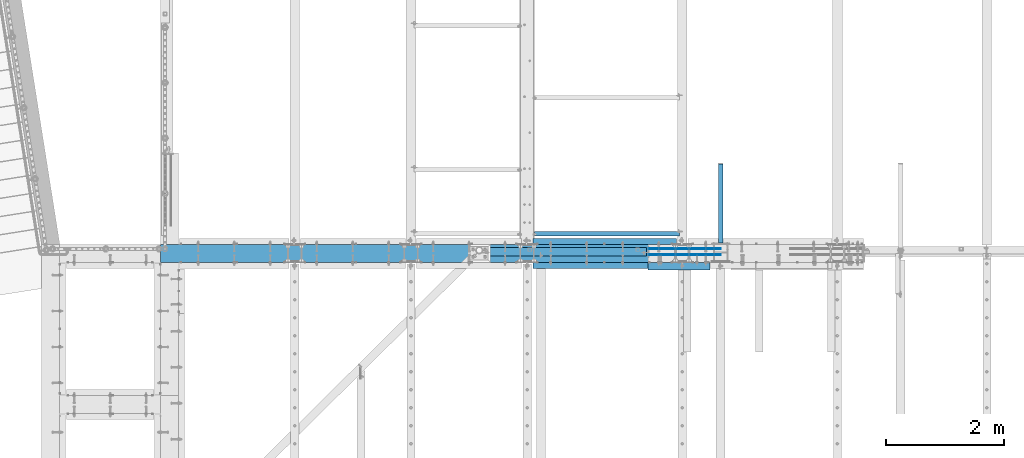
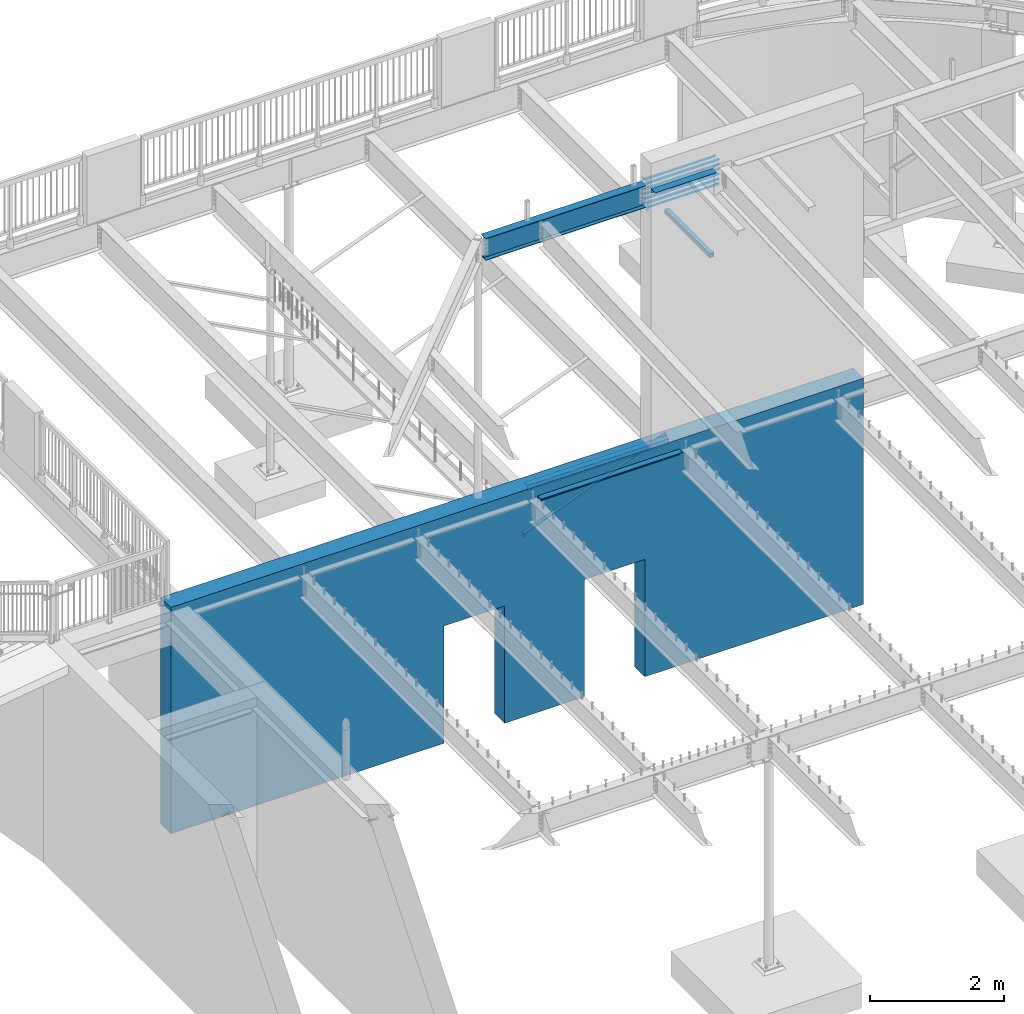
# One storey, part 320 of 975: 19 beams.
"""IFC2X3 building model written with IfcOpenShell, lengths in millimetres."""

from ifc_helpers import new_model, si_unit, frame, origin_with_axes, place, context, subcontext, project, spatial, faceted_brep, material, type_object, element, save


model = new_model("IFC2X3")

# Units and contexts
model_context = context("Model", 3, precision=1e-05, world=origin_with_axes())
body_context = subcontext(model_context, "Body", "Model", "MODEL_VIEW")
ifc_project = project(units=[si_unit("LENGTHUNIT", "METRE", prefix="MILLI"), si_unit("AREAUNIT", "SQUARE_METRE"), si_unit("VOLUMEUNIT", "CUBIC_METRE"), si_unit("MASSUNIT", "GRAM", prefix="KILO"), si_unit("TIMEUNIT", "SECOND"), si_unit("PLANEANGLEUNIT", "RADIAN"), si_unit("SOLIDANGLEUNIT", "STERADIAN"), si_unit("THERMODYNAMICTEMPERATUREUNIT", "DEGREE_CELSIUS"), si_unit("LUMINOUSINTENSITYUNIT", "LUMEN")], contexts=[model_context])

# Site, building, storey
site_placement = place(None, origin_with_axes())
site = spatial("IfcSite", under=ifc_project, at=site_placement, CompositionType="ELEMENT")
building_placement = place(site_placement, origin_with_axes())
building = spatial("IfcBuilding", under=site, at=building_placement, Name="Undefined", CompositionType="ELEMENT")
storey_placement = place(building_placement, origin_with_axes())
storey = spatial("IfcBuildingStorey", under=building, at=storey_placement, Name="Undefined", CompositionType="ELEMENT", Elevation=0.0)

# Beams
ifc_material_1 = material(Name="STEEL/A36")
beam_type_1 = type_object("IfcBeamType", Name="L3X3X3/16", PredefinedType="NOTDEFINED")
beam_1_placement = place(storey_placement, frame((8394.7, 20924.04375, 2870.2), z_axis=(0.0, -1.0, 0.0), x_axis=(0.0, 0.0, 1.0)))
element("IfcBeam", 1, at=beam_1_placement, inside=storey, type_object=beam_type_1, material=ifc_material_1, Name="ANGLE", ObjectType="L3X3X3/16", context=body_context, shape_type="Brep", body=[
    faceted_brep([(39.9761162779782, -38.1000000000186, -33.3375000000015), (39.9761162779782, -38.1000000000186, -38.0999999999985), (975.885837340196, -2441.28615210523, -38.0999999999985), (975.885837340196, -2441.28615210523, -33.3375000000015), (92.0750045805971, 38.0999999999585, 38.0999999999985), (92.0750045776413, 38.0999999999985, -38.1000000000004), (25.4000000000001, 38.0999999999985, -38.1000000000004), (25.4000000005876, 38.0999999999876, 38.0999999999985), (1046.89123738925, -2413.6334277571, 38.0999999999985), (1046.89123738925, -2413.6334277571, -38.0999999999985), (22.2348571728535, 7.45519597605016, -38.0999999999985), (88.8737698161085, 33.4074081533654, -38.0999999999985), (25.4037304659755, 33.357482595593, -38.0999999999985), (88.8737698161085, 33.4074081533654, -33.3375000000015), (22.2348571728535, 7.45519597605016, -33.3375000000015), (25.4037304659819, 33.3574825875421, -33.3375000000015), (25.4037304659746, 33.3574825966371, 38.0999999999985), (88.8188240616832, 33.3374999999596, 38.0999999999985), (1042.45405198512, -2415.36146907195, -33.3375000000015), (1042.45339988618, -2415.36172302886, 38.0999999999985)], [[[0, 1, 2, 3]], [[4, 5, 6, 7]], [[5, 4, 8, 9]], [[1, 10, 11, 12, 6, 5, 9, 2]], [[13, 11, 10, 14]], [[11, 13, 15, 12]], [[16, 7, 6, 12, 15]], [[13, 17, 16, 15]], [[17, 13, 18, 19]], [[4, 7, 16, 17, 19, 8]], [[18, 3, 2, 9, 8, 19]], [[13, 14, 0, 3, 18]], [[10, 1, 0, 14]]]),
])
beam_type_2 = type_object("IfcBeamType", Name="L4X4X5/16", PredefinedType="NOTDEFINED")
for number, where, z_axis, x_axis, name in (
    (2, (10763.249999995, 20799.4249996637, 3886.2), (0.0, 1.0, 0.0), (-0.999999999999998, 6.90000001668524e-08, 0.0), "LEDGER_ANGLE"),
    (3, (8324.84999999089, 20393.025, 3886.2), (0.0, -1.0, 0.0), (1.0, 0.0, 0.0), "LEDGER_ANGLE"),
):
    element("IfcBeam", number, at=place(storey_placement, frame(where, z_axis=z_axis, x_axis=x_axis)), inside=storey, type_object=beam_type_2, material=ifc_material_1, Name=name, ObjectType="L4X4X5/16", context=body_context, shape_type="Brep", body=[
        faceted_brep([(-1.90993887372315e-11, 50.8000000000002, -50.8), (2.00088834390044e-11, 50.8000000000002, 50.8), (2438.40000000415, 50.8000000000002, 50.7999999999993), (2438.40000000415, 50.8000000000002, -50.7999999999993), (2.00088834390044e-11, 42.8625000000002, 50.8), (2438.40000000415, 42.8625000000002, 50.7999999999993), (-1.63709046319127e-11, 42.8625000000002, -42.8625), (2438.40000000415, 42.8625000000002, -42.8624999999993), (-1.63709046319127e-11, -50.8000000000002, -42.8625), (2438.40000000415, -50.8000000000002, -42.8624999999993), (-1.90993887372315e-11, -50.8000000000002, -50.8), (2438.40000000415, -50.8000000000002, -50.7999999999993)], [[[0, 1, 2, 3]], [[1, 4, 5, 2]], [[4, 6, 7, 5]], [[6, 8, 9, 7]], [[8, 10, 11, 9]], [[10, 0, 3, 11]], [[5, 7, 9, 11, 3, 2]], [[10, 8, 6, 4, 1, 0]]]),
    ])
beam_type_3 = type_object("IfcBeamType", Name="L5X3X5/16", PredefinedType="NOTDEFINED")
beam_2_placement = place(storey_placement, frame((10274.2999999151, 20380.325, 8801.1), z_axis=(0.0, -1.0, 0.0), x_axis=(1.0, 0.0, 0.0)))
element("IfcBeam", 4, at=beam_2_placement, inside=storey, type_object=beam_type_3, material=ifc_material_1, Name="LEDGER_ANGLE", ObjectType="L5X3X5/16", context=body_context, shape_type="Brep", body=[
    faceted_brep([(5.0931703299284e-11, 38.0999999999999, -63.5000000000255), (-4.72937244921923e-11, 38.0999999999999, 63.5000000000182), (1057.27499999998, 38.1000000000004, 63.5000000004693), (1057.27500000004, 38.1000000000004, -63.4999999995307), (-3.63797880709171e-12, 30.1625000000404, 63.4999999999909), (1057.27499999998, 30.1625000000004, 63.5000000004693), (3.41060513164848e-12, 30.1624999999367, -55.5625000000091), (1057.27500000003, 30.1625000000004, -55.5624999995307), (2.27373675443232e-12, -38.1000000000313, -55.5624999999873), (1057.27500000003, -38.1000000000004, -55.5624999995307), (5.0931703299284e-11, -38.0999999999999, -63.5000000000255), (1057.27500000004, -38.1000000000004, -63.4999999995307)], [[[0, 1, 2, 3]], [[1, 4, 5, 2]], [[4, 6, 7, 5]], [[6, 8, 9, 7]], [[8, 10, 11, 9]], [[10, 0, 3, 11]], [[5, 7, 9, 11, 3, 2]], [[10, 8, 6, 4, 1, 0]]]),
])
ifc_material_2 = material(Name="STEEL/A496")
beam_type_4 = type_object("IfcBeamType", Name="#6 DBA", PredefinedType="NOTDEFINED")
for number, where, z_axis, x_axis, name in (
    (5, (10293.3500068517, 20570.8249983747, 8772.53493098976), (0.0, -1.0, 0.0), (1.0, 0.0, 0.0), "ROD"),
    (6, (10293.3500072578, 20672.4249983747, 8772.53493100593), (0.0, -1.0, 0.0), (1.0, 0.0, 0.0), "ROD"),
    (7, (10293.3500068517, 20570.8249983925, 8683.6349431141), (0.0, -1.0, 0.0), (1.0, 0.0, 0.0), "ROD"),
    (8, (10293.3500072578, 20672.4249983925, 8683.63494313028), (0.0, -1.0, 0.0), (1.0, 0.0, 0.0), "ROD"),
    (9, (10293.3500068517, 20570.8249984103, 8594.73495523845), (0.0, -1.0, 0.0), (1.0, 0.0, 0.0), "ROD"),
    (10, (10293.3500072578, 20672.4249984103, 8594.73495525462), (0.0, -1.0, 0.0), (1.0, 0.0, 0.0), "ROD"),
    (11, (10293.3500068517, 20570.8249984281, 8505.83496736279), (0.0, -1.0, 0.0), (1.0, 0.0, 0.0), "ROD"),
    (12, (10293.3500072578, 20672.4249984281, 8505.83496737896), (0.0, -1.0, 0.0), (1.0, 0.0, 0.0), "ROD"),
    (13, (10293.3500068517, 20570.824998446, 8416.93497948713), (0.0, -1.0, 0.0), (1.0, 0.0, 0.0), "ROD"),
    (14, (10293.3500072578, 20672.424998446, 8416.9349795033), (0.0, -1.0, 0.0), (1.0, 0.0, 0.0), "ROD"),
    (15, (10293.3698921169, 20570.8249983552, 8861.43491886542), (0.0, -1.0, 0.0), (1.0, 0.0, 0.0), "ROD"),
    (16, (10293.3698925231, 20672.4249983553, 8861.43491888159), (0.0, -1.0, 0.0), (1.0, 0.0, 0.0), "ROD"),
):
    element("IfcBeam", number, at=place(storey_placement, frame(where, z_axis=z_axis, x_axis=x_axis)), inside=storey, type_object=beam_type_4, material=ifc_material_2, Name=name, ObjectType="#6 DBA", context=body_context, shape_type="Brep", body=[
        faceted_brep([(0.0, -6.34999999998763, -3.63797880709171e-12), (0.0, -4.49012806052269, -4.49012806054634), (1219.19983372321, -4.49012806053543, -4.49012805836537), (1219.19983372321, -6.35000000000036, 2.16823536902666e-09), (0.0, 7.27595761418343e-12, -6.35000000000764), (1219.19983372321, 0.0, -6.34999999783395), (0.0, 4.49012806053724, -4.49012806053906), (1219.19983372321, 4.49012806053543, -4.49012805836537), (0.0, 6.34999999999491, 5.45696821063757e-12), (1219.19983372321, 6.35000000000036, 2.16823536902666e-09), (0.0, 4.49012806052633, 4.49012806054634), (1219.19983372321, 4.49012806053543, 4.49012806270184), (0.0, 0.0, 6.35000000000764), (1219.19983372321, 0.0, 6.35000000216678), (0.0, -4.49012806053361, 4.49012806053543), (1219.19983372321, -4.49012806053543, 4.49012806270184)], [[[0, 1, 2, 3]], [[1, 4, 5, 2]], [[4, 6, 7, 5]], [[6, 8, 9, 7]], [[8, 10, 11, 9]], [[10, 12, 13, 11]], [[12, 14, 15, 13]], [[14, 0, 3, 15]], [[5, 7, 9, 11, 13, 15, 3, 2]], [[14, 12, 10, 8, 6, 4, 1, 0]]]),
    ])
ifc_material_3 = material()
beam_type_5 = type_object("IfcBeamType", Name="HSS3X3X1/4", PredefinedType="NOTDEFINED")
beam_3_placement = place(storey_placement, frame((11509.375, 20646.9149014879, 6997.7), z_axis=(0.0, 0.0, -1.0), x_axis=(0.0, 1.0, 0.0)))
element("IfcBeam", 17, at=beam_3_placement, inside=storey, type_object=beam_type_5, material=ifc_material_3, Name="BEAM", ObjectType="HSS3X3X1/4", context=body_context, shape_type="Brep", body=[
    faceted_brep([(120.760098512088, 31.75, -31.75), (120.760098512088, -31.75, -31.75), (1466.84999999999, -31.75, -31.75), (1466.84999999999, 31.75, -31.75), (120.760098512088, -31.75, 31.75), (1466.84999999999, -31.75, 31.75), (120.760098512088, 31.75, 31.75), (1466.84999999999, 31.75, 31.75), (120.760098512088, 38.1000000000004, -38.1000000000004), (120.760098512088, 38.1000000000004, 38.1000000000004), (1466.84999999999, 38.1000000000004, 38.1000000000004), (1466.84999999999, 38.1000000000004, -38.1000000000004), (120.760098512088, -38.1000000000004, 38.1000000000004), (1466.84999999999, -38.1000000000004, 38.1000000000004), (120.760098512088, -38.1000000000004, -38.1000000000004), (1466.84999999999, -38.1000000000004, -38.1000000000004)], [[[0, 1, 2, 3]], [[1, 4, 5, 2]], [[4, 6, 7, 5]], [[6, 0, 3, 7]], [[8, 9, 10, 11]], [[9, 12, 13, 10]], [[12, 14, 15, 13]], [[14, 8, 11, 15]], [[13, 15, 11, 10], [5, 7, 3, 2]], [[14, 12, 9, 8], [6, 4, 1, 0]]]),
])
ifc_material_4 = material(Name="STEEL/A992")
beam_type_6 = type_object("IfcBeamType", Name="W16X26", PredefinedType="NOTDEFINED")
beam_4_placement = place(storey_placement, frame((7416.8, 20621.625, 8639.175), z_axis=(0.0, 0.0, 1.0), x_axis=(1.0, 0.0, 0.0)))
element("IfcBeam", 18, at=beam_4_placement, inside=storey, type_object=beam_type_6, material=ifc_material_4, Name="BEAM", ObjectType="W16X26", context=body_context, shape_type="Brep", body=[
    faceted_brep([(82.1593166012908, -69.8499999999985, -200.025), (82.1593166012908, 69.8499999999985, -200.025), (2832.1, 69.8499999999985, -200.025), (2832.1, -69.8499999999985, -200.025), (82.1593166012908, -69.8499999999985, -190.5), (82.1593166012908, -3.17499999999927, -190.5), (82.1593166012908, -3.17499999999927, 190.5), (82.1593166012908, -69.8499999999985, 190.5), (82.1593166012908, -69.8499999999985, 200.025), (82.1593166012908, 69.8499999999985, 200.025), (82.1593166012908, 69.8499999999985, 190.5), (82.1593166012908, 3.17499999999927, 190.5), (82.1593166012908, 3.17499999999927, -190.5), (82.1593166012908, 69.8499999999985, -190.5), (2832.1, -69.8499999999985, -190.5), (2832.1, -3.17499999999927, -190.5), (2832.1, -3.17499999999927, 190.5), (2832.1, -69.8499999999985, 190.5), (2832.1, -69.8499999999985, 200.025), (2832.1, 69.8499999999985, 200.025), (2832.1, 69.8499999999985, 190.5), (2832.1, 3.17499999999927, 190.5), (2832.1, 3.17499999999927, -190.5), (2832.1, 69.8499999999985, -190.5)], [[[0, 1, 2, 3]], [[0, 4, 5, 6, 7, 8, 9, 10, 11, 12, 13, 1]], [[5, 4, 14, 15]], [[6, 5, 15, 16]], [[7, 6, 16, 17]], [[8, 7, 17, 18]], [[9, 8, 18, 19]], [[10, 9, 19, 20]], [[11, 10, 20, 21]], [[12, 11, 21, 22]], [[13, 12, 22, 23]], [[1, 13, 23, 2]], [[22, 21, 20, 19, 18, 17, 16, 15, 14, 3, 2, 23]], [[4, 0, 3, 14]]]),
])
ifc_material_5 = material(Name="CONCRETE/5000")
beam_type_7 = type_object("IfcBeamType", PredefinedType="NOTDEFINED")
beam_5_placement = place(storey_placement, frame((13928.725, 20596.225, 2057.4), z_axis=(0.0, 0.0, 1.0), x_axis=(-0.999999999999998, 6.90000001668524e-08, 0.0)))
element("IfcBeam", 19, at=beam_5_placement, inside=storey, type_object=beam_type_7, material=ifc_material_5, Name="WALL", context=body_context, shape_type="Brep", body=[
    faceted_brep([(3759.19995117188, -152.400000000001, -2057.4), (3759.19995117188, 152.400000000001, -2057.4), (3759.19995117188, 152.400000000001, 76.2000976562499), (3759.19995117188, -152.400000000001, 76.2000976562499), (4800.59997558594, -152.400000000001, 76.2000976562499), (4800.59997558594, 152.400000000001, 76.2000976562499), (4800.59997558594, 152.400000000001, -2057.4), (4800.59997558594, -152.400000000001, -2057.4), (-4.33680868994202e-19, -152.400000000009, -2057.4), (-4.33680868994202e-19, -152.400000000009, 2057.4), (0.0, 152.399999999998, 2057.4), (0.0, 152.399999999998, -2057.4), (11912.6, -152.400000000001, 2057.4), (11912.6, 152.400000000001, 2057.4), (11912.6, -152.400000000001, -2057.4), (11912.6, 152.400000000001, -2057.4), (7213.6, -152.400000000001, -2057.4), (7213.6, 152.400000000001, -2057.4), (7213.6, -152.400000000001, 76.2000976562499), (7213.6, 152.400000000001, 76.2000976562499), (6172.19997558594, -152.400000000001, 76.2000976562499), (6172.19997558594, 152.400000000001, 76.2000976562499), (6172.19997558594, -152.400000000001, -2057.4), (6172.19997558594, 152.400000000001, -2057.4)], [[[0, 1, 2, 3]], [[4, 5, 6, 7]], [[3, 2, 5, 4]], [[8, 9, 10, 11]], [[10, 9, 12, 13]], [[12, 14, 15, 13]], [[15, 14, 16, 17]], [[18, 19, 17, 16]], [[20, 21, 19, 18]], [[22, 23, 21, 20]], [[23, 22, 7, 6]], [[1, 11, 10, 13, 15, 17, 19, 21, 23, 6, 5, 2]], [[8, 11, 1, 0]], [[22, 20, 18, 16, 14, 12, 9, 8, 0, 3, 4, 7]]]),
])

save(model, "model.ifc")
